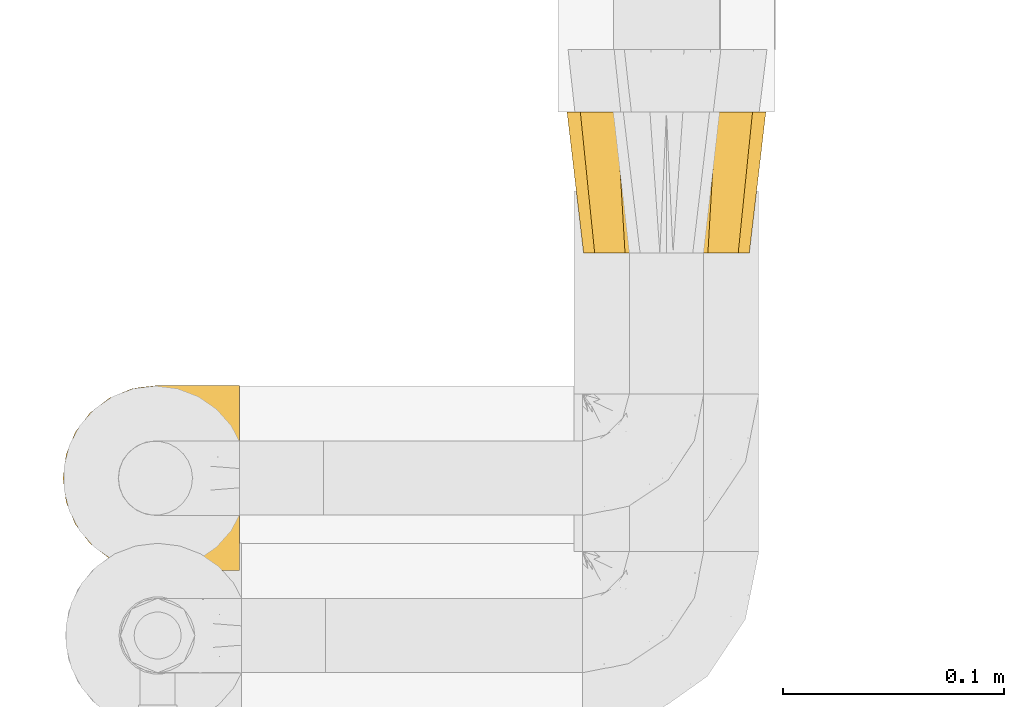
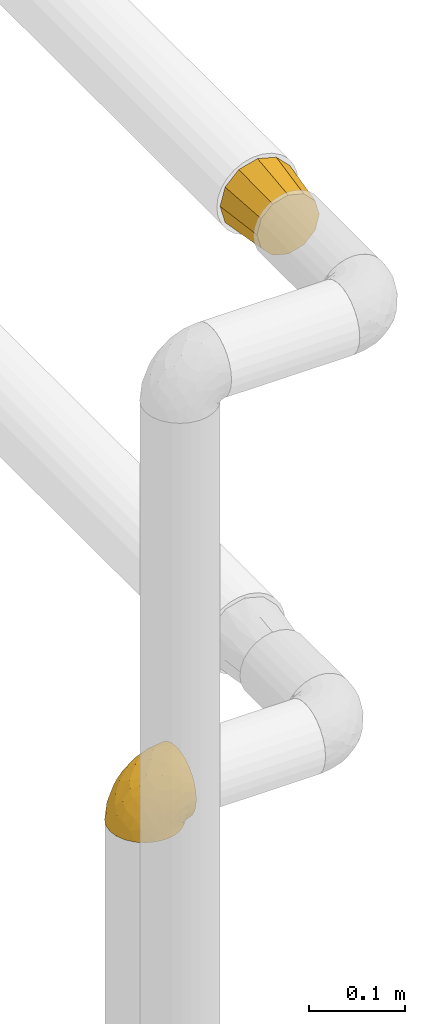
# One storey, part 124 of 827: 2 coverings.
"""IFC2X3 building model written with IfcOpenShell, lengths in millimetres."""

from ifc_helpers import new_model, entity, si_unit, converted_unit, derived_unit, direction, frame, origin, place, context, subcontext, project, spatial, faceted_brep, element, save


model = new_model("IFC2X3")

# Units and contexts
model_context = context("Model", 3, precision=0.01, world=origin(), true_north=direction((6.12303176911189e-17, 1.0)))
body_context = subcontext(model_context, "Body", "Model", "MODEL_VIEW")
ifc_project = project(units=[si_unit("LENGTHUNIT", "METRE", prefix="MILLI"), si_unit("AREAUNIT", "SQUARE_METRE"), si_unit("VOLUMEUNIT", "CUBIC_METRE"), converted_unit("PLANEANGLEUNIT", "DEGREE", entity("IfcRatioMeasure", 0.0174532925199433), si_unit("PLANEANGLEUNIT", "RADIAN"), dimensions=[0, 0, 0, 0, 0, 0, 0]), si_unit("MASSUNIT", "GRAM", prefix="KILO"), derived_unit("MASSDENSITYUNIT", [(si_unit("MASSUNIT", "GRAM", prefix="KILO"), 1), (si_unit("LENGTHUNIT", "METRE"), -3)]), derived_unit("MOMENTOFINERTIAUNIT", [(si_unit("LENGTHUNIT", "METRE"), 4)]), si_unit("TIMEUNIT", "SECOND"), si_unit("FREQUENCYUNIT", "HERTZ"), si_unit("THERMODYNAMICTEMPERATUREUNIT", "DEGREE_CELSIUS"), derived_unit("THERMALTRANSMITTANCEUNIT", [(si_unit("MASSUNIT", "GRAM", prefix="KILO"), 1), (si_unit("THERMODYNAMICTEMPERATUREUNIT", "KELVIN"), -1), (si_unit("TIMEUNIT", "SECOND"), -3)]), derived_unit("VOLUMETRICFLOWRATEUNIT", [(si_unit("LENGTHUNIT", "METRE"), 3), (si_unit("TIMEUNIT", "SECOND"), -1)]), derived_unit("MASSFLOWRATEUNIT", [(si_unit("MASSUNIT", "GRAM", prefix="KILO"), 1), (si_unit("TIMEUNIT", "SECOND"), -1)]), derived_unit("ROTATIONALFREQUENCYUNIT", [(si_unit("TIMEUNIT", "SECOND"), -1)]), si_unit("ELECTRICCURRENTUNIT", "AMPERE"), si_unit("ELECTRICVOLTAGEUNIT", "VOLT"), si_unit("POWERUNIT", "WATT"), si_unit("FORCEUNIT", "NEWTON", prefix="KILO"), si_unit("ILLUMINANCEUNIT", "LUX"), si_unit("LUMINOUSFLUXUNIT", "LUMEN"), si_unit("LUMINOUSINTENSITYUNIT", "CANDELA"), derived_unit("USERDEFINED", [(si_unit("MASSUNIT", "GRAM", prefix="KILO"), -1), (si_unit("LENGTHUNIT", "METRE"), -2), (si_unit("TIMEUNIT", "SECOND"), 3), (si_unit("LUMINOUSFLUXUNIT", "LUMEN"), 1)]), derived_unit("LINEARVELOCITYUNIT", [(si_unit("LENGTHUNIT", "METRE"), 1), (si_unit("TIMEUNIT", "SECOND"), -1)]), si_unit("PRESSUREUNIT", "PASCAL"), derived_unit("USERDEFINED", [(si_unit("LENGTHUNIT", "METRE"), -2), (si_unit("MASSUNIT", "GRAM", prefix="KILO"), 1), (si_unit("TIMEUNIT", "SECOND"), -2)]), derived_unit("LINEARFORCEUNIT", [(si_unit("MASSUNIT", "GRAM", prefix="KILO"), 1), (si_unit("LENGTHUNIT", "METRE"), 1), (si_unit("TIMEUNIT", "SECOND"), -2), (si_unit("LENGTHUNIT", "METRE"), -1)]), derived_unit("PLANARFORCEUNIT", [(si_unit("MASSUNIT", "GRAM", prefix="KILO"), 1), (si_unit("LENGTHUNIT", "METRE"), 1), (si_unit("TIMEUNIT", "SECOND"), -2), (si_unit("LENGTHUNIT", "METRE"), -2)])], contexts=[model_context])

# Site, building, storey
site_placement = place(None, origin())
site = spatial("IfcSite", under=ifc_project, at=site_placement, CompositionType="ELEMENT")
building_placement = place(site_placement, origin())
building = spatial("IfcBuilding", under=site, at=building_placement, CompositionType="ELEMENT")
storey_placement = place(building_placement, frame((0.0, 0.0, 28200.0)))
storey = spatial("IfcBuildingStorey", under=building, at=storey_placement, Name="08", CompositionType="ELEMENT", Elevation=28200.0)

# Coverings
covering_1_placement = place(storey_placement, frame((11958.87, 16667.69, 2223.69)))
element("IfcCovering", 1, at=covering_1_placement, inside=storey, Name=":ADSK_", ObjectType=":ADSK_", PredefinedType="INSULATION", context=body_context, shape_type="Brep", body=[
    faceted_brep([(9.1, 0.0, 46.6), (11.61, 0.0, 37.22), (14.12, 0.0, 27.85), (20.98, 0.0, 20.98), (27.85, 0.0, 14.12), (37.22, 0.0, 11.61), (46.6, 0.0, 9.1), (55.97, 0.0, 11.61), (65.35, 0.0, 14.12), (72.21, 0.0, 20.98), (79.07, 0.0, 27.85), (81.58, 0.0, 37.22), (84.1, 0.0, 46.6), (81.58, 0.0, 55.97), (79.07, 0.0, 65.35), (72.21, 0.0, 72.21), (65.35, 0.0, 79.07), (55.97, 0.0, 81.58), (46.6, 0.0, 84.1), (37.22, 0.0, 81.58), (27.85, 0.0, 79.07), (20.98, 0.0, 72.21), (14.12, 0.0, 65.35), (11.61, 0.0, 55.97), (77.33, 64.0, 77.33), (85.57, 64.0, 69.1), (88.1, 64.0, 59.65), (91.6, 64.0, 46.6), (88.1, 64.0, 33.54), (85.57, 64.0, 24.1), (77.33, 64.0, 15.86), (69.1, 64.0, 7.62), (59.65, 64.0, 5.09), (46.6, 64.0, 1.6), (33.54, 64.0, 5.09), (24.1, 64.0, 7.62), (15.86, 64.0, 15.86), (7.62, 64.0, 24.1), (5.09, 64.0, 33.54), (1.6, 64.0, 46.6), (5.09, 64.0, 59.65), (7.62, 64.0, 69.1), (15.86, 64.0, 77.33), (24.1, 64.0, 85.57), (33.54, 64.0, 88.1), (46.6, 64.0, 91.6), (59.65, 64.0, 88.1), (69.1, 64.0, 85.57)], [[[0, 1, 2, 3, 4, 5, 6, 7, 8, 9, 10, 11, 12, 13, 14, 15, 16, 17, 18, 19, 20, 21, 22, 23]], [[24, 25, 26, 27, 28, 29, 30, 31, 32, 33, 34, 35, 36, 37, 38, 39, 40, 41, 42, 43, 44, 45, 46, 47]], [[4, 35, 34, 33, 6, 5]], [[37, 36, 35, 4, 3, 2]], [[1, 0, 39, 38, 37, 2]], [[10, 29, 28, 27, 12, 11]], [[31, 30, 29, 10, 9, 8]], [[7, 6, 33, 32, 31, 8]], [[16, 47, 46, 45, 18, 17]], [[25, 24, 47, 16, 15, 14]], [[13, 12, 27, 26, 25, 14]], [[22, 41, 40, 39, 0, 23]], [[43, 42, 41, 22, 21, 20]], [[19, 18, 45, 44, 43, 20]]]),
])
covering_2_placement = place(storey_placement, frame((11730.77, 16522.41, 1654.67)))
element("IfcCovering", 2, at=covering_2_placement, inside=storey, Name=":ADSK_", ObjectType=":ADSK_", PredefinedType="INSULATION", context=body_context, shape_type="Brep", body=[
    faceted_brep([(81.45, 81.15, 57.76), (81.45, 76.16, 65.69), (81.45, 69.53, 72.32), (81.45, 61.6, 77.3), (81.45, 52.75, 80.4), (81.45, 43.45, 81.45), (81.45, 34.13, 80.39), (81.45, 25.28, 77.3), (81.45, 17.35, 72.31), (81.45, 10.72, 65.68), (81.45, 5.74, 57.75), (81.45, 2.64, 48.9), (81.45, 1.6, 39.6), (81.45, 2.66, 30.22), (81.45, 5.79, 21.33), (81.45, 10.83, 13.37), (81.45, 17.53, 6.73), (81.45, 25.53, 1.77), (81.45, 26.45, 1.77), (81.45, 27.37, 1.77), (81.45, 28.17, 1.77), (81.45, 29.49, 1.77), (81.45, 30.81, 1.77), (81.45, 32.13, 1.77), (81.45, 33.45, 1.77), (81.45, 34.78, 1.77), (81.45, 36.1, 1.77), (81.45, 37.42, 1.77), (81.45, 38.74, 1.77), (81.45, 40.06, 1.77), (81.45, 41.38, 1.77), (81.45, 42.7, 1.77), (81.45, 44.02, 1.77), (81.45, 45.34, 1.77), (81.45, 46.66, 1.77), (81.45, 47.58, 1.77), (81.45, 48.5, 1.77), (81.45, 49.41, 1.77), (81.45, 50.33, 1.77), (81.45, 51.25, 1.77), (81.45, 52.17, 1.77), (81.45, 53.09, 1.77), (81.45, 54.01, 1.77), (81.45, 54.93, 1.77), (81.45, 55.85, 1.77), (81.45, 56.76, 1.77), (81.45, 57.68, 1.77), (81.45, 58.6, 1.77), (81.45, 59.52, 1.77), (81.45, 60.44, 1.77), (81.45, 61.36, 1.77), (81.45, 69.37, 6.74), (81.45, 76.07, 13.38), (81.45, 81.11, 21.35), (81.45, 84.24, 30.24), (81.45, 85.3, 39.6), (81.45, 84.24, 48.91), (76.3, 17.52, 1.6), (69.67, 10.83, 1.6), (61.7, 5.79, 1.6), (52.81, 2.66, 1.6), (43.45, 1.6, 1.6), (32.61, 3.02, 1.6), (22.52, 7.2, 1.6), (13.85, 13.85, 1.6), (7.2, 22.52, 1.6), (3.02, 32.61, 1.6), (1.6, 43.45, 1.6), (3.02, 54.28, 1.6), (7.2, 64.37, 1.6), (13.85, 73.04, 1.6), (22.52, 79.69, 1.6), (32.61, 83.87, 1.6), (43.45, 85.3, 1.6), (52.81, 84.23, 1.6), (61.7, 81.1, 1.6), (69.67, 76.06, 1.6), (76.3, 69.37, 1.6), (81.27, 61.36, 1.6), (81.27, 60.44, 1.6), (81.27, 59.12, 1.6), (81.27, 58.0, 1.6), (81.27, 56.88, 1.6), (81.27, 55.76, 1.6), (81.27, 54.64, 1.6), (81.27, 53.52, 1.6), (81.27, 52.4, 1.6), (81.27, 51.28, 1.6), (81.27, 50.16, 1.6), (81.27, 49.04, 1.6), (81.27, 47.92, 1.6), (81.27, 46.8, 1.6), (81.27, 45.68, 1.6), (81.27, 44.56, 1.6), (81.27, 43.45, 1.6), (81.27, 42.12, 1.6), (81.27, 40.8, 1.6), (81.27, 39.48, 1.6), (81.27, 38.16, 1.6), (81.27, 36.84, 1.6), (81.27, 35.52, 1.6), (81.27, 34.2, 1.6), (81.27, 32.88, 1.6), (81.27, 31.96, 1.6), (81.27, 31.05, 1.6), (81.27, 30.13, 1.6), (81.27, 29.21, 1.6), (81.27, 28.29, 1.6), (81.27, 27.37, 1.6), (81.27, 26.45, 1.6), (81.27, 25.53, 1.6), (81.31, 54.08, 1.71), (81.33, 55.16, 1.73), (81.31, 36.18, 1.71), (81.32, 35.13, 1.72), (81.31, 44.01, 1.71), (81.32, 45.08, 1.72), (81.32, 61.36, 1.72), (81.32, 59.98, 1.72), (81.32, 46.18, 1.72), (81.32, 26.74, 1.72), (81.32, 47.36, 1.72), (81.32, 29.67, 1.72), (81.3, 28.72, 1.7), (81.32, 39.77, 1.72), (81.33, 52.96, 1.73), (81.31, 51.84, 1.72), (81.33, 40.8, 1.73), (81.32, 41.87, 1.73), (81.32, 42.94, 1.72), (81.32, 27.77, 1.72), (81.31, 48.4, 1.71), (81.32, 37.21, 1.72), (81.31, 33.54, 1.71), (81.32, 32.49, 1.72), (81.32, 30.69, 1.72), (81.32, 50.69, 1.72), (81.33, 49.6, 1.73), (81.32, 56.32, 1.72), (81.31, 57.44, 1.71), (81.33, 58.88, 1.73), (81.32, 25.53, 1.72), (81.36, 61.36, 1.74), (81.4, 61.36, 1.75), (81.4, 25.53, 1.75), (81.36, 25.53, 1.74), (81.29, 61.36, 1.64), (81.3, 61.36, 1.68), (81.3, 25.53, 1.68), (81.29, 25.53, 1.64), (81.35, 31.59, 1.74), (81.31, 38.71, 1.71), (58.5, 3.97, 8.98), (71.95, 1.6, 37.05), (74.57, 3.97, 24.69), (73.93, 8.09, 15.28), (78.18, 8.09, 16.86), (78.04, 16.43, 6.58), (76.23, 15.73, 5.71), (45.99, 1.6, 11.1), (74.01, 10.79, 10.79), (73.57, 13.99, 4.13), (66.66, 8.08, 6.62), (79.09, 14.0, 9.52), (73.14, 12.83, 6.14), (60.34, 3.18, 17.79), (48.54, 1.6, 20.6), (45.36, 1.6, 8.73), (67.22, 3.28, 23.66), (62.45, 1.6, 34.5), (68.67, 6.28, 15.32), (55.49, 1.6, 27.55), (77.84, 19.06, 3.31), (68.16, 8.08, 9.81), (74.31, 1.6, 37.68), (38.78, 32.11, 67.23), (62.1, 29.62, 76.64), (50.89, 43.45, 75.37), (36.91, 2.45, 14.58), (40.37, 2.5, 23.71), (27.86, 9.73, 34.34), (15.77, 17.97, 29.1), (20.13, 10.24, 18.02), (31.54, 4.78, 22.27), (28.25, 4.78, 10.97), (57.26, 8.01, 56.79), (69.99, 8.01, 60.76), (64.58, 13.85, 67.04), (50.64, 2.42, 36.11), (51.97, 21.17, 68.85), (5.72, 35.73, 24.58), (7.42, 27.43, 21.54), (66.14, 43.45, 78.4), (11.35, 17.97, 14.11), (21.64, 35.71, 53.42), (28.57, 29.47, 58.19), (55.38, 3.41, 44.49), (68.51, 3.94, 51.77), (67.48, 21.17, 73.69), (40.78, 7.92, 45.89), (41.53, 4.25, 35.97), (46.11, 11.75, 56.55), (40.32, 18.31, 60.03), (38.36, 24.94, 63.64), (11.84, 28.78, 34.98), (12.56, 35.82, 40.58), (7.67, 43.45, 32.15), (19.39, 28.38, 47.26), (24.98, 43.45, 58.06), (37.94, 43.45, 66.71), (4.64, 43.45, 16.9), (28.09, 21.21, 52.08), (23.73, 16.48, 41.21), (34.03, 13.85, 49.76), (16.33, 43.45, 45.11), (29.29, 82.11, 15.65), (5.77, 51.41, 24.57), (21.44, 57.45, 50.54), (38.8, 54.78, 67.25), (64.58, 73.03, 67.06), (67.49, 65.7, 73.7), (22.9, 76.65, 26.13), (12.54, 68.92, 19.54), (20.04, 68.01, 38.96), (57.26, 78.88, 56.8), (69.99, 78.88, 60.77), (68.51, 82.94, 51.78), (34.54, 64.44, 59.09), (38.81, 84.49, 19.25), (48.54, 85.3, 20.6), (45.99, 85.3, 11.1), (74.31, 85.3, 37.68), (5.36, 57.84, 15.21), (18.96, 76.65, 12.76), (12.79, 51.19, 40.93), (62.11, 57.26, 76.65), (33.14, 78.14, 39.5), (33.44, 82.35, 25.01), (51.98, 65.7, 68.86), (43.42, 84.61, 26.7), (48.62, 84.36, 34.95), (62.45, 85.3, 34.5), (55.49, 85.3, 27.55), (49.68, 73.03, 61.27), (55.37, 83.48, 44.5), (71.95, 85.3, 37.05), (36.37, 84.54, 10.25), (34.04, 73.03, 49.78), (44.1, 79.54, 47.51), (9.99, 59.46, 29.38), (26.41, 73.5, 40.01), (39.19, 82.57, 33.36), (58.5, 82.92, 8.98), (67.22, 83.62, 23.67), (74.57, 82.92, 24.71), (73.92, 78.81, 15.29), (73.57, 72.9, 4.13), (73.14, 74.06, 6.14), (66.19, 78.81, 4.96), (68.16, 78.81, 9.81), (77.84, 67.83, 3.31), (76.23, 71.15, 5.7), (79.08, 72.91, 9.53), (78.04, 70.47, 6.59), (77.18, 78.81, 16.63), (68.66, 80.62, 15.34), (74.0, 76.11, 10.8), (60.34, 83.71, 17.79)], [[[0, 1, 2, 3, 4, 5, 6, 7, 8, 9, 10, 11, 12, 13, 14, 15, 16, 17, 18, 19, 20, 21, 22, 23, 24, 25, 26, 27, 28, 29, 30, 31, 32, 33, 34, 35, 36, 37, 38, 39, 40, 41, 42, 43, 44, 45, 46, 47, 48, 49, 50, 51, 52, 53, 54, 55, 56]], [[57, 58, 59, 60, 61, 62, 63, 64, 65, 66, 67, 68, 69, 70, 71, 72, 73, 74, 75, 76, 77, 78, 79, 80, 81, 82, 83, 84, 85, 86, 87, 88, 89, 90, 91, 92, 93, 94, 95, 96, 97, 98, 99, 100, 101, 102, 103, 104, 105, 106, 107, 108, 109, 110]], [[111, 84, 112]], [[113, 26, 114]], [[114, 101, 100]], [[115, 93, 116]], [[79, 117, 118]], [[33, 116, 119]], [[117, 49, 118]], [[19, 18, 120]], [[119, 121, 34]], [[122, 21, 123]], [[97, 96, 124]], [[86, 125, 126]], [[116, 92, 119]], [[127, 96, 128]], [[32, 129, 115]], [[19, 120, 130]], [[121, 90, 131]], [[94, 115, 129]], [[115, 116, 32]], [[118, 49, 48]], [[113, 99, 132]], [[133, 114, 25]], [[24, 134, 133]], [[135, 22, 122]], [[136, 137, 88]], [[84, 83, 112]], [[138, 82, 139]], [[130, 20, 19]], [[118, 48, 140]], [[81, 140, 139]], [[123, 21, 20]], [[141, 120, 18]], [[139, 82, 81]], [[130, 107, 123]], [[49, 117, 142, 143, 50]], [[18, 17, 144, 145, 141]], [[79, 78, 146, 147]], [[109, 148, 149, 110]], [[102, 133, 134]], [[105, 135, 122]], [[109, 141, 148]], [[79, 147, 117]], [[118, 80, 79]], [[80, 118, 140]], [[120, 109, 108]], [[47, 46, 140, 48]], [[81, 80, 140]], [[44, 112, 138]], [[93, 115, 94]], [[46, 139, 140]], [[46, 45, 139]], [[139, 45, 138]], [[138, 112, 83]], [[85, 84, 111]], [[112, 43, 111]], [[83, 82, 138]], [[106, 122, 123]], [[105, 122, 106]], [[21, 122, 22]], [[124, 29, 28]], [[33, 32, 116]], [[128, 129, 31]], [[32, 31, 129]], [[34, 33, 119]], [[116, 93, 92]], [[129, 95, 94]], [[95, 129, 128]], [[41, 40, 125, 42]], [[119, 91, 121]], [[36, 35, 131, 37]], [[137, 131, 89]], [[121, 131, 35]], [[90, 121, 91]], [[119, 92, 91]], [[136, 126, 39]], [[125, 86, 85]], [[42, 125, 111]], [[85, 111, 125]], [[150, 23, 22]], [[130, 108, 107]], [[130, 123, 20]], [[107, 106, 123]], [[137, 37, 131]], [[136, 38, 137]], [[89, 88, 137]], [[131, 90, 89]], [[124, 151, 97]], [[40, 39, 126]], [[87, 126, 136]], [[86, 126, 87]], [[136, 88, 87]], [[40, 126, 125]], [[39, 38, 136]], [[95, 128, 96]], [[30, 128, 31]], [[29, 124, 127]], [[127, 128, 30]], [[151, 124, 28]], [[127, 30, 29]], [[127, 124, 96]], [[151, 98, 97]], [[45, 44, 138]], [[26, 113, 132]], [[113, 100, 99]], [[132, 151, 27]], [[27, 26, 132]], [[26, 25, 114]], [[100, 113, 114]], [[101, 133, 102]], [[133, 101, 114]], [[28, 27, 151]], [[132, 99, 98]], [[23, 134, 24]], [[25, 24, 133]], [[134, 23, 150]], [[135, 104, 150]], [[150, 104, 103]], [[103, 102, 134]], [[130, 120, 108]], [[109, 120, 141]], [[42, 111, 43]], [[112, 44, 43]], [[104, 135, 105]], [[134, 150, 103]], [[135, 150, 22]], [[35, 34, 121]], [[137, 38, 37]], [[98, 151, 132]], [[59, 152, 60]], [[13, 153, 154]], [[155, 156, 154]], [[157, 158, 141]], [[159, 60, 152]], [[160, 157, 155]], [[161, 162, 58]], [[58, 162, 59]], [[144, 16, 163]], [[58, 57, 161]], [[162, 161, 164]], [[157, 163, 155]], [[163, 16, 15]], [[57, 149, 161]], [[152, 165, 166]], [[157, 144, 163]], [[60, 159, 167, 61]], [[156, 14, 154]], [[163, 156, 155]], [[155, 154, 168]], [[168, 154, 169]], [[155, 170, 160]], [[57, 110, 149]], [[144, 17, 16]], [[156, 15, 14]], [[171, 165, 168]], [[158, 164, 172]], [[14, 13, 154]], [[157, 141, 145, 144]], [[173, 164, 158]], [[173, 160, 170]], [[171, 166, 165]], [[168, 165, 170]], [[168, 169, 171]], [[152, 173, 165]], [[170, 155, 168]], [[165, 173, 170]], [[160, 173, 158]], [[172, 149, 148]], [[148, 141, 158]], [[158, 157, 160]], [[152, 166, 159]], [[173, 152, 162]], [[59, 162, 152]], [[13, 12, 174, 153]], [[153, 169, 154]], [[15, 156, 163]], [[162, 164, 173]], [[172, 164, 161]], [[149, 172, 161]], [[158, 172, 148]], [[175, 176, 177]], [[178, 166, 179]], [[180, 181, 182]], [[183, 184, 178]], [[185, 186, 187]], [[171, 188, 179]], [[174, 12, 11]], [[189, 176, 175]], [[190, 66, 191]], [[176, 6, 192]], [[193, 65, 64]], [[63, 184, 182]], [[63, 182, 64]], [[65, 193, 191]], [[184, 63, 62]], [[175, 194, 195]], [[196, 169, 197]], [[174, 11, 197]], [[8, 7, 198]], [[187, 9, 8]], [[197, 169, 153, 174]], [[197, 11, 10]], [[186, 197, 10]], [[199, 180, 200]], [[197, 185, 196]], [[201, 189, 202]], [[201, 187, 189]], [[195, 203, 175]], [[191, 204, 190]], [[176, 7, 6]], [[177, 176, 192]], [[189, 198, 176]], [[65, 191, 66]], [[198, 187, 8]], [[205, 206, 190]], [[9, 186, 10]], [[181, 207, 204]], [[208, 175, 177, 209]], [[66, 190, 210]], [[211, 212, 213]], [[190, 204, 205]], [[180, 182, 183]], [[193, 182, 181]], [[62, 61, 167]], [[196, 185, 199]], [[196, 200, 188]], [[6, 5, 192]], [[176, 198, 7]], [[187, 198, 189]], [[187, 186, 9]], [[197, 186, 185]], [[200, 180, 183]], [[180, 213, 212]], [[179, 183, 178]], [[185, 201, 199]], [[210, 190, 206]], [[210, 67, 66]], [[205, 204, 207]], [[194, 205, 207]], [[194, 214, 205]], [[195, 194, 207]], [[208, 194, 175]], [[207, 211, 195]], [[202, 203, 211]], [[212, 207, 181]], [[202, 211, 213]], [[201, 202, 213]], [[189, 175, 203]], [[199, 201, 213]], [[187, 201, 185]], [[180, 199, 213]], [[196, 199, 200]], [[211, 203, 195]], [[189, 203, 202]], [[207, 212, 211]], [[180, 212, 181]], [[214, 194, 208]], [[214, 206, 205]], [[196, 188, 169]], [[181, 204, 191]], [[182, 193, 64]], [[191, 193, 181]], [[178, 62, 167]], [[182, 184, 183]], [[62, 178, 184]], [[178, 167, 159, 166]], [[171, 179, 166]], [[200, 183, 179]], [[179, 188, 200]], [[169, 188, 171]], [[71, 215, 72]], [[206, 216, 210]], [[217, 208, 218]], [[216, 68, 210]], [[219, 220, 2]], [[221, 222, 223]], [[224, 225, 226]], [[227, 223, 217]], [[228, 229, 230]], [[56, 231, 226]], [[232, 222, 69]], [[56, 55, 231]], [[70, 233, 71]], [[71, 233, 215]], [[0, 56, 226]], [[208, 217, 234]], [[218, 177, 235]], [[221, 236, 237]], [[238, 220, 219]], [[1, 219, 2]], [[68, 216, 232]], [[235, 3, 220]], [[235, 192, 4]], [[1, 0, 225]], [[228, 239, 229]], [[240, 241, 242]], [[243, 238, 219]], [[224, 226, 244]], [[226, 241, 244]], [[3, 235, 4]], [[69, 222, 70]], [[225, 219, 1]], [[218, 235, 238]], [[243, 219, 224]], [[218, 227, 217]], [[3, 2, 220]], [[218, 208, 209, 177]], [[226, 231, 245, 241]], [[215, 228, 246]], [[247, 248, 236]], [[248, 224, 244]], [[223, 222, 249]], [[233, 222, 221]], [[242, 239, 240]], [[248, 247, 243]], [[217, 223, 249]], [[250, 247, 236]], [[216, 234, 249]], [[218, 238, 227]], [[192, 235, 177]], [[192, 5, 4]], [[72, 246, 73]], [[235, 220, 238]], [[226, 225, 0]], [[219, 225, 224]], [[240, 248, 244]], [[239, 242, 229]], [[236, 248, 251]], [[68, 67, 210]], [[234, 216, 206]], [[216, 249, 232]], [[234, 206, 214, 208]], [[249, 234, 217]], [[222, 232, 249]], [[69, 68, 232]], [[246, 228, 230]], [[237, 228, 215]], [[243, 227, 238]], [[223, 227, 247]], [[73, 246, 230]], [[215, 246, 72]], [[248, 243, 224]], [[227, 243, 247]], [[237, 236, 251]], [[250, 221, 223]], [[222, 233, 70]], [[215, 233, 221]], [[221, 237, 215]], [[239, 237, 251]], [[237, 239, 228]], [[239, 251, 240]], [[248, 240, 251]], [[241, 240, 244]], [[221, 250, 236]], [[223, 247, 250]], [[74, 230, 252]], [[253, 254, 255]], [[146, 77, 256]], [[257, 258, 259]], [[260, 256, 257]], [[260, 261, 147]], [[75, 74, 252]], [[51, 143, 262]], [[263, 143, 142, 117]], [[256, 77, 76]], [[252, 258, 75]], [[253, 241, 254]], [[254, 245, 54]], [[258, 256, 76]], [[53, 52, 264]], [[255, 265, 253]], [[254, 264, 255]], [[255, 264, 262]], [[75, 258, 76]], [[265, 255, 266]], [[255, 262, 263]], [[51, 50, 143]], [[54, 245, 231, 55]], [[51, 262, 52]], [[253, 267, 242]], [[254, 54, 53]], [[266, 259, 265]], [[146, 78, 77]], [[263, 117, 261]], [[146, 256, 260]], [[257, 259, 261]], [[267, 253, 265]], [[229, 267, 252]], [[242, 267, 229]], [[242, 241, 253]], [[252, 267, 259]], [[255, 263, 266]], [[259, 267, 265]], [[261, 117, 147]], [[263, 261, 266]], [[259, 266, 261]], [[230, 74, 73]], [[230, 229, 252]], [[259, 258, 252]], [[254, 241, 245]], [[53, 264, 254]], [[52, 262, 264]], [[143, 263, 262]], [[258, 257, 256]], [[261, 260, 257]], [[146, 260, 147]]]),
])

save(model, "model.ifc")
